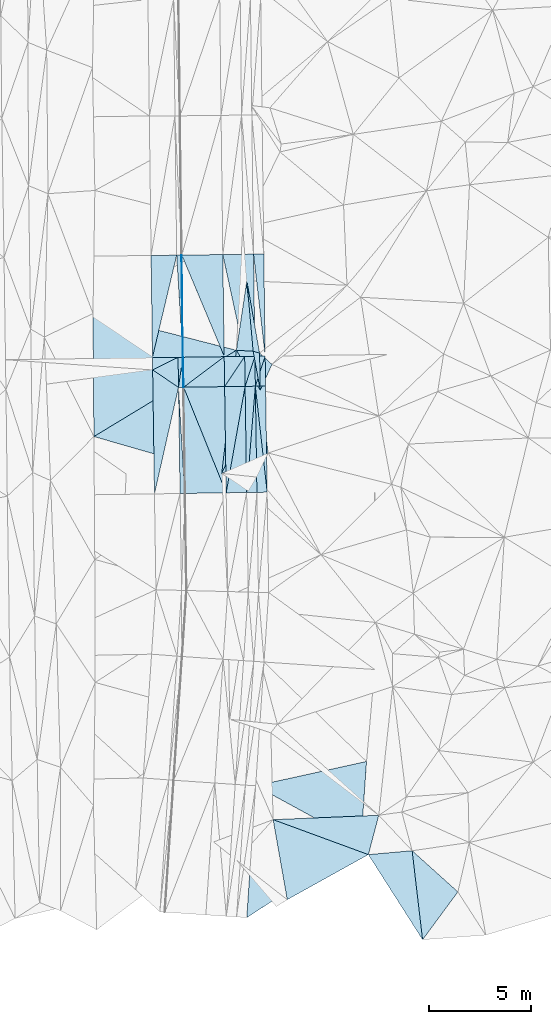
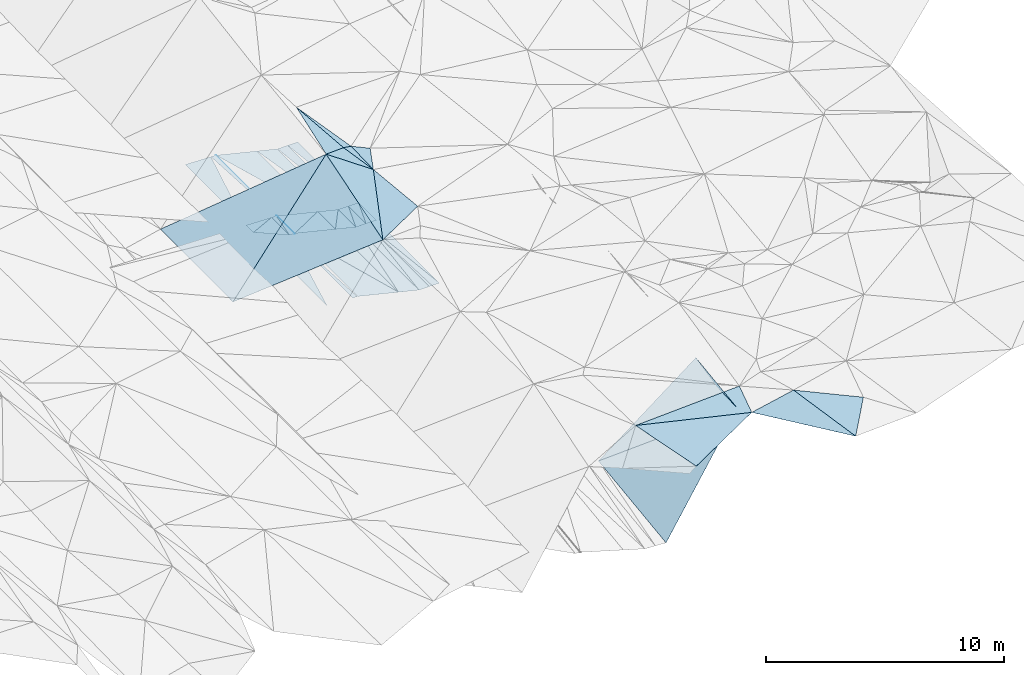
# One storey, part 28 of 275: 46 plates.
"""IFC2X3 building model written with IfcOpenShell, lengths in millimetres."""

import ifcopenshell
import ifcopenshell.guid

model = None  # the IFC model being written
_history = None  # IfcOwnerHistory: only IFC2X3 demands one
_inside = {}  # id of a spatial element -> (the spatial element, [elements in it])
_under = {}  # id of a project, library or spatial element -> (it, [spatial elements below it])
_declared = {}  # id of a project -> (the project, [libraries it declares])
_typed = {}  # id of a type object -> (the type object, [elements of that type])
_made_of = {}  # id of a material, layer set ... -> (it, [elements and type objects made of it])


def new_model(schema):
    """Start an empty IFC model of exactly this schema.

    Asked for "IFC4X3", IfcOpenShell would pick the latest addendum, in which some entities
    have other attributes; the version numbers below select the first issue.
    IFC2X3 requires an IfcOwnerHistory on every rooted entity: one is made here for all.
    """
    global model, _history
    if schema == "IFC4X3":
        model = ifcopenshell.file(schema_version=(4, 3, 0, 0))
    else:
        model = ifcopenshell.file(schema=schema)
    _inside.clear()
    _under.clear()
    _declared.clear()
    _typed.clear()
    _made_of.clear()
    _history = None
    if model.schema == "IFC2X3":
        org = make("IfcOrganization", Name="unknown")
        user = make(
            "IfcPersonAndOrganization",
            ThePerson=make("IfcPerson", FamilyName="unknown"),
            TheOrganization=org,
        )
        app = make(
            "IfcApplication",
            ApplicationDeveloper=org,
            Version="unknown",
            ApplicationFullName="unknown",
            ApplicationIdentifier="unknown",
        )
        _history = make(
            "IfcOwnerHistory",
            OwningUser=user,
            OwningApplication=app,
            ChangeAction="ADDED",
            CreationDate=0,
        )
    return model


def make(cls, **values):
    """One entity of the class cls with the attributes given. An attribute that is None is left unset."""
    return model.create_entity(
        cls, **{name: value for name, value in values.items() if value is not None}
    )


def rooted(cls, **values):
    """An entity with a GlobalId (a new one), such as an element, a storey or a relation."""
    return make(cls, GlobalId=ifcopenshell.guid.new(), OwnerHistory=_history, **values)


def si_unit(unit_type, name, prefix=None):
    """IfcSIUnit, for example si_unit("LENGTHUNIT", "METRE", prefix="MILLI")."""
    return make("IfcSIUnit", UnitType=unit_type, Prefix=prefix, Name=name)


def assignment(units):
    """IfcUnitAssignment: the units of a project."""
    return None if units is None else make("IfcUnitAssignment", Units=units)


def point(xyz):
    """IfcCartesianPoint."""
    return None if xyz is None else make("IfcCartesianPoint", Coordinates=xyz)


def direction(xyz):
    """IfcDirection."""
    return None if xyz is None else make("IfcDirection", DirectionRatios=xyz)


def frame(location, z_axis=None, x_axis=None):
    """IfcAxis2Placement3D, a coordinate frame: its origin and axes. An axis left out is left unset."""
    return make(
        "IfcAxis2Placement3D",
        Location=point(location),
        Axis=direction(z_axis),
        RefDirection=direction(x_axis),
    )


def origin_with_axes():
    """The frame at (0, 0, 0) with the z axis (0, 0, 1) and the x axis (1, 0, 0) written out."""
    return frame((0.0, 0.0, 0.0), z_axis=(0.0, 0.0, 1.0), x_axis=(1.0, 0.0, 0.0))


def place(relative_to, where):
    """IfcLocalPlacement: puts the frame where relative to a parent placement (None: the world)."""
    return make(
        "IfcLocalPlacement", PlacementRelTo=relative_to, RelativePlacement=where
    )


def context(
    kind, dimensions, precision=None, world=None, true_north=None, identifier=None
):
    """IfcGeometricRepresentationContext, for example the 3D "Model" context."""
    return make(
        "IfcGeometricRepresentationContext",
        ContextIdentifier=identifier,
        ContextType=kind,
        CoordinateSpaceDimension=dimensions,
        Precision=precision,
        WorldCoordinateSystem=world,
        TrueNorth=true_north,
    )


def subcontext(parent, identifier, kind, view, scale=None):
    """IfcGeometricRepresentationSubContext, for example "Body" below "Model"."""
    return make(
        "IfcGeometricRepresentationSubContext",
        ContextIdentifier=identifier,
        ContextType=kind,
        ParentContext=parent,
        TargetScale=scale,
        TargetView=view,
    )


def project(units=None, contexts=None):
    """IfcProject with its units and contexts."""
    return rooted(
        "IfcProject",
        Name="project",
        RepresentationContexts=contexts,
        UnitsInContext=assignment(units),
    )


def spatial(cls, under=None, at=None, **own):
    """A site, building, storey or space (cls), placed at a placement, below another one or the project."""
    s = rooted(cls, ObjectPlacement=at, **own)
    if under is not None:
        _under.setdefault(under.id(), (under, []))[1].append(s)
    return s


def polyline(points):
    """IfcPolyline through the points."""
    return make("IfcPolyline", Points=[point(p) for p in points])


def outline(outer, holes=None, kind="AREA"):
    """IfcArbitraryClosedProfileDef: a profile drawn as a closed curve; with holes, ...WithVoids."""
    if holes is None:
        return make("IfcArbitraryClosedProfileDef", ProfileType=kind, OuterCurve=outer)
    return make(
        "IfcArbitraryProfileDefWithVoids",
        ProfileType=kind,
        OuterCurve=outer,
        InnerCurves=holes,
    )


def extrude(swept, where, along, depth):
    """IfcExtrudedAreaSolid: the profile swept, set in the frame where, extruded along a direction by depth."""
    return make(
        "IfcExtrudedAreaSolid",
        SweptArea=swept,
        Position=where,
        ExtrudedDirection=direction(along),
        Depth=depth,
    )


def shape(context_of_items, identifier, shape_type, items):
    """IfcShapeRepresentation: the items that make up one representation, for example the "Body"."""
    return make(
        "IfcShapeRepresentation",
        ContextOfItems=context_of_items,
        RepresentationIdentifier=identifier,
        RepresentationType=shape_type,
        Items=items,
    )


def material(Name=None, Category=None):
    """IfcMaterial."""
    return make("IfcMaterial", Name=Name, Category=Category)


def made_of(thing, what):
    """Note that an element or type object is made of a material, layer set ...; save() writes the relation."""
    if what is not None:
        _made_of.setdefault(what.id(), (what, []))[1].append(thing)
    return thing


def type_object(cls, material=None, **own):
    """A type object (cls), such as IfcWallType, which elements share."""
    return made_of(rooted(cls, **own), material)


def element(
    cls,
    number,
    at=None,
    inside=None,
    cuts=None,
    type_object=None,
    material=None,
    context=None,
    identifier="Body",
    shape_type=None,
    held_by="IfcProductDefinitionShape",
    body=None,
    shapes=None,
    **own,
):
    """One element of the class cls, such as IfcWall. Its Tag is "e" and its number.

    at: its placement. inside: the storey or other place that contains it. cuts: it is an
    opening in that element (IfcRelVoidsElement). A single representation is given by context,
    identifier, shape_type and body (its items); several are given by shapes. held_by: the class
    of the entity that holds the representations. save() writes the other relations.
    """
    e = rooted(cls, Tag="e%d" % number, ObjectPlacement=at, **own)
    if body is not None:
        shapes = [shape(context, identifier, shape_type, body)]
    if shapes is not None:
        e.Representation = make(held_by, Representations=shapes)
    if inside is not None:
        _inside.setdefault(inside.id(), (inside, []))[1].append(e)
    if cuts is not None:
        rooted(
            "IfcRelVoidsElement", RelatingBuildingElement=cuts, RelatedOpeningElement=e
        )
    if type_object is not None:
        _typed.setdefault(type_object.id(), (type_object, []))[1].append(e)
    return made_of(e, material)


def aggregate(whole, parts):
    """IfcRelAggregates: a whole, such as a stair, and the parts it consists of."""
    return rooted("IfcRelAggregates", RelatingObject=whole, RelatedObjects=parts)


def save(model, path):
    """Write the relations noted so far, then the file.

    IfcRelAggregates (storeys below a building ...), IfcRelContainedInSpatialStructure (elements
    in a storey), IfcRelDefinesByType, IfcRelAssociatesMaterial and IfcRelDeclares: one each for
    every whole, place, type object, material and project.
    """
    for whole, parts in _under.values():
        aggregate(whole, parts)
    for where, things in _inside.values():
        rooted(
            "IfcRelContainedInSpatialStructure",
            RelatedElements=things,
            RelatingStructure=where,
        )
    for kind, things in _typed.values():
        rooted("IfcRelDefinesByType", RelatedObjects=things, RelatingType=kind)
    for what, things in _made_of.values():
        rooted("IfcRelAssociatesMaterial", RelatedObjects=things, RelatingMaterial=what)
    for by, libraries in _declared.values():
        rooted("IfcRelDeclares", RelatingContext=by, RelatedDefinitions=libraries)
    model.write(path)


model = new_model("IFC2X3")

# Units and contexts
model_context = context("Model", 3, precision=1e-05, world=origin_with_axes())
body_context = subcontext(model_context, "Body", "Model", "MODEL_VIEW")
ifc_project = project(units=[si_unit("LENGTHUNIT", "METRE", prefix="MILLI"), si_unit("AREAUNIT", "SQUARE_METRE"), si_unit("VOLUMEUNIT", "CUBIC_METRE"), si_unit("MASSUNIT", "GRAM", prefix="KILO"), si_unit("TIMEUNIT", "SECOND"), si_unit("PLANEANGLEUNIT", "RADIAN"), si_unit("SOLIDANGLEUNIT", "STERADIAN"), si_unit("THERMODYNAMICTEMPERATUREUNIT", "DEGREE_CELSIUS"), si_unit("LUMINOUSINTENSITYUNIT", "LUMEN")], contexts=[model_context])

# Site, building, storey
site_placement = place(None, origin_with_axes())
site = spatial("IfcSite", under=ifc_project, at=site_placement, CompositionType="ELEMENT")
building_placement = place(site_placement, origin_with_axes())
building = spatial("IfcBuilding", under=site, at=building_placement, Name="Undefined", CompositionType="ELEMENT")
storey_placement = place(building_placement, origin_with_axes())
storey = spatial("IfcBuildingStorey", under=building, at=storey_placement, Name="Undefined", CompositionType="ELEMENT", Elevation=0.0)

# Plates
ifc_material = material()
plate_type_1 = type_object("IfcPlateType", PredefinedType="NOTDEFINED")
plate_1_placement = place(storey_placement, frame((-56941.8178044151, -6357.65182748982, 40803.0364137105), z_axis=(-0.0353297863927327, 0.0204032928486913, -0.999167409313562), x_axis=(-0.0145680960377885, 0.999674825691065, 0.0209287710430521)))
element("IfcPlate", 1, at=plate_1_placement, inside=storey, type_object=plate_type_1, material=ifc_material, Name="00_PR", context=body_context, shape_type="SweptSolid", body=[
    extrude(outline(polyline([(0.0, 0.0), (6049.75830078125, -2.35013430938125e-09), (5183.77392578125, 1250.3623046875), (0.0, 0.0)])), frame((-8.85201319254618e-08, 2.18876761149539e-07, -0.5000001331573), z_axis=(0.0, 0.0, 1.0), x_axis=(1.0, 0.0, 0.0)), (0.0, 0.0, 1.0), 1.0),
])
plate_type_2 = type_object("IfcPlateType", PredefinedType="NOTDEFINED")
plate_2_placement = place(storey_placement, frame((-55558.864264753, 333.224894072824, 40889.1297464698), z_axis=(-0.050207080738683, 0.021132013568532, -0.998515241268875), x_axis=(-0.0135497510538627, 0.999669703891426, 0.0218377509832748)))
element("IfcPlate", 2, at=plate_2_placement, inside=storey, type_object=plate_type_2, material=ifc_material, Name="00_PR", context=body_context, shape_type="SweptSolid", body=[
    extrude(outline(polyline([(0.0, 0.0), (4962.09521484375, 3.05590219795704e-10), (4962.06494140625, 20.0251941680908), (0.0, 0.0)])), frame((-8.85201319254618e-08, 2.18876761149539e-07, -0.5000001331573), z_axis=(0.0, 0.0, 1.0), x_axis=(1.0, 0.0, 0.0)), (0.0, 0.0, 1.0), 1.0),
])
plate_3_placement = place(storey_placement, frame((-55517.9188380509, -1152.88416207165, 40855.2377295211), z_axis=(-0.0496313828432934, 0.0213955677100842, -0.998538409636518), x_axis=(-0.0277638170463829, 0.999354615861594, 0.0227930300561567)))
element("IfcPlate", 3, at=plate_3_placement, inside=storey, type_object=plate_type_2, material=ifc_material, Name="00_PR", context=body_context, shape_type="SweptSolid", body=[
    extrude(outline(polyline([(0.0, 0.0), (1462.376953125, 1.30967237055302e-10), (1462.0791015625, 20.0225772857666), (0.0, 0.0)])), frame((-8.85201319254618e-08, 2.18876761149539e-07, -0.5000001331573), z_axis=(0.0, 0.0, 1.0), x_axis=(1.0, 0.0, 0.0)), (0.0, 0.0, 1.0), 1.0),
])
plate_4_placement = place(storey_placement, frame((-55517.9191398334, -1152.88417101758, 40855.2377443623), z_axis=(-0.0502343597940609, 0.0213781283682467, -0.99850863026994), x_axis=(-0.998651445147197, -0.0141938470544001, 0.0499382199443619)))
element("IfcPlate", 4, at=plate_4_placement, inside=storey, type_object=plate_type_2, material=ifc_material, Name="00_PR", context=body_context, shape_type="SweptSolid", body=[
    extrude(outline(polyline([(0.0, 0.0), (20.0247211456299, -8.70841176947579e-11), (21.4675941467285, 1462.21936035156), (0.0, 0.0)])), frame((-8.85201319254618e-08, 2.18876761149539e-07, -0.5000001331573), z_axis=(0.0, 0.0, 1.0), x_axis=(1.0, 0.0, 0.0)), (0.0, 0.0, 1.0), 1.0),
])
plate_type_3 = type_object("IfcPlateType", PredefinedType="NOTDEFINED")
plate_5_placement = place(storey_placement, frame((-51606.4208821664, 5346.49573586657, 40246.4901238692), z_axis=(-0.000287064842259564, 0.0218505512888936, -0.999761206990023), x_axis=(0.0135494950592206, -0.999669386481595, -0.0218524349936422)))
element("IfcPlate", 5, at=plate_5_placement, inside=storey, type_object=plate_type_3, material=ifc_material, Name="00_PR", context=body_context, shape_type="SweptSolid", body=[
    extrude(outline(polyline([(0.0, 0.0), (4958.7607421875, -1.94268068298697e-09), (-0.208078876137733, 500.0), (0.0, 0.0)])), frame((-8.85201319254618e-08, 2.18876761149539e-07, -0.5000001331573), z_axis=(0.0, 0.0, 1.0), x_axis=(1.0, 0.0, 0.0)), (0.0, 0.0, 1.0), 1.0),
])
plate_6_placement = place(storey_placement, frame((-52106.3777888769, 5339.92747869403, 40246.490123646), z_axis=(-0.000287081021315416, 0.0218487238851854, -0.999761246923022), x_axis=(0.0135496300479079, -0.999669424588275, -0.021850607975812)))
element("IfcPlate", 6, at=plate_6_placement, inside=storey, type_object=plate_type_3, material=ifc_material, Name="00_PR", context=body_context, shape_type="SweptSolid", body=[
    extrude(outline(polyline([(0.0, 0.0), (4959.17578125, 1.5788828022778e-09), (-0.207226857542992, 499.999603271484), (0.0, 0.0)])), frame((-8.85201319254618e-08, 2.18876761149539e-07, -0.5000001331573), z_axis=(0.0, 0.0, 1.0), x_axis=(1.0, 0.0, 0.0)), (0.0, 0.0, 1.0), 1.0),
])
plate_7_placement = place(storey_placement, frame((-51538.8784994366, 364.063115143073, 40137.5531222983), z_axis=(-0.000314517182269425, 0.0221231376374528, -0.999755203967459), x_axis=(0.0140906790476609, -0.999655901113563, -0.0221253730546399)))
element("IfcPlate", 7, at=plate_7_placement, inside=storey, type_object=plate_type_3, material=ifc_material, Name="00_PR", context=body_context, shape_type="SweptSolid", body=[
    extrude(outline(polyline([(0.0, 0.0), (1460.58557128906, -3.63797880709171e-11), (1460.64611816406, 500.000762939453), (0.0, 0.0)])), frame((-8.85201319254618e-08, 2.18876761149539e-07, -0.5000001331573), z_axis=(0.0, 0.0, 1.0), x_axis=(1.0, 0.0, 0.0)), (0.0, 0.0, 1.0), 1.0),
])
plate_8_placement = place(storey_placement, frame((-51518.2978468996, -1096.02060175882, 40105.237106606), z_axis=(-0.000293615235016061, 0.0206529359838606, -0.999786662256174), x_axis=(0.0146461580413869, -0.999679378681155, -0.0206550210430108)))
element("IfcPlate", 8, at=plate_8_placement, inside=storey, type_object=plate_type_3, material=ifc_material, Name="00_PR", context=body_context, shape_type="SweptSolid", body=[
    extrude(outline(polyline([(0.0, 0.0), (5180.33837890625, 2.69210431724787e-10), (-0.217007249593735, 500.000732421875), (0.0, 0.0)])), frame((-8.85201319254618e-08, 2.18876761149539e-07, -0.5000001331573), z_axis=(0.0, 0.0, 1.0), x_axis=(1.0, 0.0, 0.0)), (0.0, 0.0, 1.0), 1.0),
])
plate_9_placement = place(storey_placement, frame((-52038.830471524, 357.164657838352, 40137.5551221029), z_axis=(-0.000314515267574764, 0.0221213384723832, -0.999755243779365), x_axis=(0.0140898400447904, -0.999655952755373, -0.0221235740390148)))
element("IfcPlate", 9, at=plate_9_placement, inside=storey, type_object=plate_type_3, material=ifc_material, Name="00_PR", context=body_context, shape_type="SweptSolid", body=[
    extrude(outline(polyline([(0.0, 0.0), (1460.79467773438, 1.45519152283669e-11), (1460.85620117188, 499.999450683594), (0.0, 0.0)])), frame((-8.85201319254618e-08, 2.18876761149539e-07, -0.5000001331573), z_axis=(0.0, 0.0, 1.0), x_axis=(1.0, 0.0, 0.0)), (0.0, 0.0, 1.0), 1.0),
])
plate_10_placement = place(storey_placement, frame((-52018.2481057998, -1103.1282245535, 40105.2371062211), z_axis=(-0.000311525496391537, 0.0206509464012298, -0.999786697933414), x_axis=(0.0146462390507561, -0.99967941317538, -0.0206532940470902)))
element("IfcPlate", 10, at=plate_10_placement, inside=storey, type_object=plate_type_3, material=ifc_material, Name="00_PR", context=body_context, shape_type="SweptSolid", body=[
    extrude(outline(polyline([(0.0, 0.0), (5180.77197265625, 4.07453626394272e-10), (5180.98876953125, 499.999908447266), (0.0, 0.0)])), frame((-8.85201319254618e-08, 2.18876761149539e-07, -0.5000001331573), z_axis=(0.0, 0.0, 1.0), x_axis=(1.0, 0.0, 0.0)), (0.0, 0.0, 1.0), 1.0),
])
plate_11_placement = place(storey_placement, frame((-52018.2481044546, -1103.12748920171, 40105.2371218576), z_axis=(-0.000309235493463831, 0.0221214128853827, -0.999755243779878), x_axis=(-0.0140898400448231, 0.999655952755456, 0.0221235740352296)))
element("IfcPlate", 11, at=plate_11_placement, inside=storey, type_object=plate_type_3, material=ifc_material, Name="00_PR", context=body_context, shape_type="SweptSolid", body=[
    extrude(outline(polyline([(0.0, 0.0), (1460.79467773438, 1.45519152283669e-11), (1460.646484375, 499.999542236328), (0.0, 0.0)])), frame((-8.85201319254618e-08, 2.18876761149539e-07, -0.5000001331573), z_axis=(0.0, 0.0, 1.0), x_axis=(1.0, 0.0, 0.0)), (0.0, 0.0, 1.0), 1.0),
])
plate_12_placement = place(storey_placement, frame((-51942.3692855471, -6282.23909670942, 39998.2371056729), z_axis=(-0.000311525496391537, 0.0206509464012298, -0.999786697933414), x_axis=(-0.0146462390505551, 0.999679413175508, 0.0206532940410656)))
element("IfcPlate", 12, at=plate_12_placement, inside=storey, type_object=plate_type_3, material=ifc_material, Name="00_PR", context=body_context, shape_type="SweptSolid", body=[
    extrude(outline(polyline([(0.0, 0.0), (5180.77197265625, 4.07453626394272e-10), (0.216174393892288, 500.000305175781), (0.0, 0.0)])), frame((-8.85201319254618e-08, 2.18876761149539e-07, -0.5000001331573), z_axis=(0.0, 0.0, 1.0), x_axis=(1.0, 0.0, 0.0)), (0.0, 0.0, 1.0), 1.0),
])
plate_13_placement = place(storey_placement, frame((-52518.1970335013, -1110.2356233127, 40105.237121261), z_axis=(-0.00030536461958494, 0.0221183511351763, -0.999755312711821), x_axis=(-0.014090546045561, 0.99965601176035, 0.0221204580316273)))
element("IfcPlate", 13, at=plate_13_placement, inside=storey, type_object=plate_type_3, material=ifc_material, Name="00_PR", context=body_context, shape_type="SweptSolid", body=[
    extrude(outline(polyline([(0.0, 0.0), (1461.09094238281, 3.63797880709171e-11), (1460.85583496094, 500.00048828125), (0.0, 0.0)])), frame((-8.85201319254618e-08, 2.18876761149539e-07, -0.5000001331573), z_axis=(0.0, 0.0, 1.0), x_axis=(1.0, 0.0, 0.0)), (0.0, 0.0, 1.0), 1.0),
])
plate_14_placement = place(storey_placement, frame((-52442.3123578305, -6289.78089681646, 39998.2371054212), z_axis=(-0.000293588266677345, 0.0206494800090892, -0.999786733649374), x_axis=(-0.0146461420537325, 0.999679450316034, 0.020651565044169)))
element("IfcPlate", 14, at=plate_14_placement, inside=storey, type_object=plate_type_3, material=ifc_material, Name="00_PR", context=body_context, shape_type="SweptSolid", body=[
    extrude(outline(polyline([(0.0, 0.0), (5181.20556640625, 2.40106601268053e-10), (5180.98876953125, 499.999420166016), (0.0, 0.0)])), frame((-8.85201319254618e-08, 2.18876761149539e-07, -0.5000001331573), z_axis=(0.0, 0.0, 1.0), x_axis=(1.0, 0.0, 0.0)), (0.0, 0.0, 1.0), 1.0),
])
plate_type_4 = type_object("IfcPlateType", PredefinedType="NOTDEFINED")
plate_15_placement = place(storey_placement, frame((-52606.4555192209, 5333.35633804358, 40246.5050406188), z_axis=(-0.242737735417362, 0.0179086597421493, -0.969926632127756), x_axis=(0.0135495010582724, -0.999669466247102, -0.0218487819868052)))
element("IfcPlate", 15, at=plate_15_placement, inside=storey, type_object=plate_type_4, material=ifc_material, Name="00_PR", context=body_context, shape_type="SweptSolid", body=[
    extrude(outline(polyline([(0.0, 0.0), (4959.58984375, 1.04773789644241e-09), (-5.8770489692688, 1030.76025390625), (0.0, 0.0)])), frame((-8.85201319254618e-08, 2.18876761149539e-07, -0.5000001331573), z_axis=(0.0, 0.0, 1.0), x_axis=(1.0, 0.0, 0.0)), (0.0, 0.0, 1.0), 1.0),
])
plate_type_5 = type_object("IfcPlateType", PredefinedType="NOTDEFINED")
plate_16_placement = place(storey_placement, frame((-55606.1971806718, 5293.94233465812, 40996.5050405204), z_axis=(-0.242737861908812, 0.0179050894554546, -0.969926666386449), x_axis=(0.970058767212209, 0.01274581605249, -0.242535631048069)))
element("IfcPlate", 16, at=plate_16_placement, inside=storey, type_object=plate_type_5, material=ifc_material, Name="00_PR", context=body_context, shape_type="SweptSolid", body=[
    extrude(outline(polyline([(0.0, 0.0), (2061.552734375, -7.5924617704004e-09), (2089.82958984375, 4960.33935546875), (0.0, 0.0)])), frame((-8.85201319254618e-08, 2.18876761149539e-07, -0.5000001331573), z_axis=(0.0, 0.0, 1.0), x_axis=(1.0, 0.0, 0.0)), (0.0, 0.0, 1.0), 1.0),
])
plate_type_6 = type_object("IfcPlateType", PredefinedType="NOTDEFINED")
plate_17_placement = place(storey_placement, frame((-55626.0994221338, 5293.68124695893, 40997.4907460091), z_axis=(-0.050207080738683, 0.021132013568532, -0.998515241268875), x_axis=(0.0135497510559135, -0.999669703891641, -0.0218377509721336)))
element("IfcPlate", 17, at=plate_17_placement, inside=storey, type_object=plate_type_6, material=ifc_material, Name="00_PR", context=body_context, shape_type="SweptSolid", body=[
    extrude(outline(polyline([(0.0, 0.0), (4962.09521484375, 3.05590219795704e-10), (-0.346415966749191, 230.286651611328), (0.0, 0.0)])), frame((-8.85201319254618e-08, 2.18876761149539e-07, -0.5000001331573), z_axis=(0.0, 0.0, 1.0), x_axis=(1.0, 0.0, 0.0)), (0.0, 0.0, 1.0), 1.0),
])
plate_18_placement = place(storey_placement, frame((-55558.5203039692, 308.548932031358, 40888.5697445091), z_axis=(-0.0502343597940609, 0.0213781283682467, -0.99850863026994), x_axis=(0.0140905100449485, -0.999656208614616, -0.0221115830488006)))
element("IfcPlate", 18, at=plate_18_placement, inside=storey, type_object=plate_type_6, material=ifc_material, Name="00_PR", context=body_context, shape_type="SweptSolid", body=[
    extrude(outline(polyline([(0.0, 0.0), (1462.21997070313, -8.00355337560177e-11), (1461.994140625, 230.287643432617), (0.0, 0.0)])), frame((-8.85201319254618e-08, 2.18876761149539e-07, -0.5000001331573), z_axis=(0.0, 0.0, 1.0), x_axis=(1.0, 0.0, 0.0)), (0.0, 0.0, 1.0), 1.0),
])
plate_19_placement = place(storey_placement, frame((-55691.9674013513, -6338.7991663607, 40760.7377279265), z_axis=(-0.0502325611855882, 0.0198808556331222, -0.998539654383356), x_axis=(-0.0146461610550057, 0.999679665323876, 0.0206411410608503)))
element("IfcPlate", 19, at=plate_19_placement, inside=storey, type_object=plate_type_6, material=ifc_material, Name="00_PR", context=body_context, shape_type="SweptSolid", body=[
    extrude(outline(polyline([(0.0, 0.0), (5184.0205078125, 4.80213202536106e-10), (-0.138187646865845, 230.287048339844), (0.0, 0.0)])), frame((-8.85201319254618e-08, 2.18876761149539e-07, -0.5000001331573), z_axis=(0.0, 0.0, 1.0), x_axis=(1.0, 0.0, 0.0)), (0.0, 0.0, 1.0), 1.0),
])
plate_type_7 = type_object("IfcPlateType", PredefinedType="NOTDEFINED")
plate_20_placement = place(storey_placement, frame((-57038.7119892179, 312.553596358796, 40943.3394093187), z_axis=(-0.0341671885636603, 0.0212943011414639, -0.999189249323947), x_axis=(-0.0135491480650036, 0.999671235842545, 0.0217678849627542)))
element("IfcPlate", 20, at=plate_20_placement, inside=storey, type_object=plate_type_7, material=ifc_material, Name="00_PR", context=body_context, shape_type="SweptSolid", body=[
    extrude(outline(polyline([(0.0, 0.0), (4968.55810546875, -8.73114913702011e-11), (4961.87451171875, 1250.71508789063), (0.0, 0.0)])), frame((-8.85201319254618e-08, 2.18876761149539e-07, -0.5000001331573), z_axis=(0.0, 0.0, 1.0), x_axis=(1.0, 0.0, 0.0)), (0.0, 0.0, 1.0), 1.0),
])
plate_type_8 = type_object("IfcPlateType", PredefinedType="NOTDEFINED")
plate_21_placement = place(storey_placement, frame((-52518.3182624784, -1110.2384421541, 40105.2520260959), z_axis=(-0.242762746308585, 0.0164806416583718, -0.9699456878894), x_axis=(0.0146461420534593, -0.999679450316063, -0.0206515650429951)))
element("IfcPlate", 21, at=plate_21_placement, inside=storey, type_object=plate_type_8, material=ifc_material, Name="00_PR", context=body_context, shape_type="SweptSolid", body=[
    extrude(outline(polyline([(0.0, 0.0), (5181.20556640625, 2.40106601268053e-10), (5176.4755859375, 1030.76501464844), (0.0, 0.0)])), frame((-8.85201319254618e-08, 2.18876761149539e-07, -0.5000001331573), z_axis=(0.0, 0.0, 1.0), x_axis=(1.0, 0.0, 0.0)), (0.0, 0.0, 1.0), 1.0),
])
plate_22_placement = place(storey_placement, frame((-53442.3192450636, -6304.86526505675, 40248.2520255617), z_axis=(-0.242746185292985, 0.0164776026975475, -0.969949884341993), x_axis=(-0.014646228053211, 0.999679520300063, 0.0206481160508506)))
element("IfcPlate", 22, at=plate_22_placement, inside=storey, type_object=plate_type_8, material=ifc_material, Name="00_PR", context=body_context, shape_type="SweptSolid", body=[
    extrude(outline(polyline([(0.0, 0.0), (5182.07080078125, -2.69210431724787e-10), (5176.47607421875, 1030.76110839844), (0.0, 0.0)])), frame((-8.85201319254618e-08, 2.18876761149539e-07, -0.5000001331573), z_axis=(0.0, 0.0, 1.0), x_axis=(1.0, 0.0, 0.0)), (0.0, 0.0, 1.0), 1.0),
])
plate_type_9 = type_object("IfcPlateType", PredefinedType="NOTDEFINED")
plate_23_placement = place(storey_placement, frame((-55767.8940519455, -1156.43844057982, 40867.7377433844), z_axis=(-0.0502125545366383, 0.0213750292553393, -0.998509793387746), x_axis=(-0.0140900000523677, 0.99965629232914, 0.0221081230610403)))
element("IfcPlate", 23, at=plate_23_placement, inside=storey, type_object=plate_type_9, material=ifc_material, Name="00_PR", context=body_context, shape_type="SweptSolid", body=[
    extrude(outline(polyline([(0.0, 0.0), (1462.494140625, 2.91038304567337e-11), (1461.99438476563, 230.286636352539), (0.0, 0.0)])), frame((-8.85201319254618e-08, 2.18876761149539e-07, -0.5000001331573), z_axis=(0.0, 0.0, 1.0), x_axis=(1.0, 0.0, 0.0)), (0.0, 0.0, 1.0), 1.0),
])
plate_type_10 = type_object("IfcPlateType", PredefinedType="NOTDEFINED")
plate_24_placement = place(storey_placement, frame((-53538.8127869472, 336.726269089667, 40387.576039377), z_axis=(-0.242760500225327, 0.0180346048840314, -0.969918600995478), x_axis=(0.0140904320510461, -0.999656151138897, -0.0221142310465747)))
element("IfcPlate", 24, at=plate_24_placement, inside=storey, type_object=plate_type_10, material=ifc_material, Name="00_PR", context=body_context, shape_type="SweptSolid", body=[
    extrude(outline(polyline([(0.0, 0.0), (1461.68322753906, -7.27595761418343e-11), (1450.86975097656, 2061.52490234375), (0.0, 0.0)])), frame((-8.85201319254618e-08, 2.18876761149539e-07, -0.5000001331573), z_axis=(0.0, 0.0, 1.0), x_axis=(1.0, 0.0, 0.0)), (0.0, 0.0, 1.0), 1.0),
])
plate_type_11 = type_object("IfcPlateType", PredefinedType="NOTDEFINED")
plate_25_placement = place(storey_placement, frame((-46592.4673051098, -19414.0699580774, 42440.9737190631), z_axis=(0.44679726660557, -0.0115737995490838, -0.894560366726466), x_axis=(-0.0696235519876854, -0.997333561490274, -0.0218707140657269)))
element("IfcPlate", 25, at=plate_25_placement, inside=storey, type_object=plate_type_11, material=ifc_material, Name="00_PR", context=body_context, shape_type="SweptSolid", body=[
    extrude(outline(polyline([(0.0, 0.0), (4000.966796875, 6.87941792421043e-09), (1619.91870117188, 5939.57373046875), (0.0, 0.0)])), frame((-8.85201319254618e-08, 2.18876761149539e-07, -0.5000001331573), z_axis=(0.0, 0.0, 1.0), x_axis=(1.0, 0.0, 0.0)), (0.0, 0.0, 1.0), 1.0),
])
plate_type_12 = type_object("IfcPlateType", PredefinedType="NOTDEFINED")
plate_26_placement = place(storey_placement, frame((-52437.5449152699, -27037.5333085249, 39609.4268694112), z_axis=(0.447436526296145, -0.0101232041352685, -0.894258394243004), x_axis=(0.0673666259477489, 0.99747647292743, 0.0224148090482824)))
element("IfcPlate", 26, at=plate_26_placement, inside=storey, type_object=plate_type_12, material=ifc_material, Name="00_PR", context=body_context, shape_type="SweptSolid", body=[
    extrude(outline(polyline([(0.0, 0.0), (6452.1181640625, -1.04555510915816e-08), (4060.50170898438, 5935.326171875), (0.0, 0.0)])), frame((-8.85201319254618e-08, 2.18876761149539e-07, -0.5000001331573), z_axis=(0.0, 0.0, 1.0), x_axis=(1.0, 0.0, 0.0)), (0.0, 0.0, 1.0), 1.0),
])
plate_type_13 = type_object("IfcPlateType", PredefinedType="NOTDEFINED")
plate_27_placement = place(storey_placement, frame((-52538.9058308175, 350.35067244107, 40137.5720397911), z_axis=(-0.242760661852887, 0.0180406158143761, -0.969918448756279), x_axis=(0.014090546045543, -0.999656011760378, -0.0221204580303599)))
element("IfcPlate", 27, at=plate_27_placement, inside=storey, type_object=plate_type_13, material=ifc_material, Name="00_PR", context=body_context, shape_type="SweptSolid", body=[
    extrude(outline(polyline([(0.0, 0.0), (1461.09094238281, 3.63797880709171e-11), (1455.68347167969, 1030.76208496094), (0.0, 0.0)])), frame((-8.85201319254618e-08, 2.18876761149539e-07, -0.5000001331573), z_axis=(0.0, 0.0, 1.0), x_axis=(1.0, 0.0, 0.0)), (0.0, 0.0, 1.0), 1.0),
])
plate_type_14 = type_object("IfcPlateType", PredefinedType="NOTDEFINED")
plate_28_placement = place(storey_placement, frame((-55538.6181291643, 308.827429177637, 40887.5960397212), z_axis=(-0.242764359156254, 0.0180400678709986, -0.969917533543272), x_axis=(0.970045823005158, 0.0135328950537076, -0.242544762923695)))
element("IfcPlate", 28, at=plate_28_placement, inside=storey, type_object=plate_type_14, material=ifc_material, Name="00_PR", context=body_context, shape_type="SweptSolid", body=[
    extrude(outline(polyline([(0.0, 0.0), (2061.5576171875, -6.18456397205591e-10), (8.049241065979, 1462.19409179688), (0.0, 0.0)])), frame((-8.85201319254618e-08, 2.18876761149539e-07, -0.5000001331573), z_axis=(0.0, 0.0, 1.0), x_axis=(1.0, 0.0, 0.0)), (0.0, 0.0, 1.0), 1.0),
])
plate_type_15 = type_object("IfcPlateType", PredefinedType="NOTDEFINED")
plate_29_placement = place(storey_placement, frame((-55518.0153960463, -1152.88662022841, 40855.2520233953), z_axis=(-0.242746185292985, 0.0164776026975475, -0.969949884341993), x_axis=(0.970044481623155, 0.0137913040481929, -0.242535571834554)))
element("IfcPlate", 29, at=plate_29_placement, inside=storey, type_object=plate_type_15, material=ifc_material, Name="00_PR", context=body_context, shape_type="SweptSolid", body=[
    extrude(outline(polyline([(0.0, 0.0), (2061.55322265625, 1.61162461154163e-09), (2089.68408203125, 5181.99462890625), (0.0, 0.0)])), frame((-8.85201319254618e-08, 2.18876761149539e-07, -0.5000001331573), z_axis=(0.0, 0.0, 1.0), x_axis=(1.0, 0.0, 0.0)), (0.0, 0.0, 1.0), 1.0),
])
plate_type_16 = type_object("IfcPlateType", PredefinedType="NOTDEFINED")
plate_30_placement = place(storey_placement, frame((-53442.3192450636, -6304.86526505675, 40248.2520255617), z_axis=(-0.242762442029136, 0.016470587454615, -0.969945934827787), x_axis=(-0.970032164370089, -0.0146323480620336, 0.242535553017846)))
element("IfcPlate", 30, at=plate_30_placement, inside=storey, type_object=plate_type_16, material=ifc_material, Name="00_PR", context=body_context, shape_type="SweptSolid", body=[
    extrude(outline(polyline([(0.0, 0.0), (2061.55346679688, 3.43152350978926e-09), (2085.32568359375, 5183.75), (0.0, 0.0)])), frame((-8.85201319254618e-08, 2.18876761149539e-07, -0.5000001331573), z_axis=(0.0, 0.0, 1.0), x_axis=(1.0, 0.0, 0.0)), (0.0, 0.0, 1.0), 1.0),
])
plate_type_17 = type_object("IfcPlateType", PredefinedType="NOTDEFINED")
plate_31_placement = place(storey_placement, frame((-53518.2170344438, -1124.45433388774, 40355.2520384637), z_axis=(-0.242752338591244, 0.018034765048291, -0.969920640752703), x_axis=(-0.0140904320506905, 0.999656151138891, 0.0221142310470777)))
element("IfcPlate", 31, at=plate_31_placement, inside=storey, type_object=plate_type_17, material=ifc_material, Name="00_PR", context=body_context, shape_type="SweptSolid", body=[
    extrude(outline(polyline([(0.0, 0.0), (1461.68322753906, -7.27595761418343e-11), (1455.68518066406, 1030.759765625), (0.0, 0.0)])), frame((-8.85201319254618e-08, 2.18876761149539e-07, -0.5000001331573), z_axis=(0.0, 0.0, 1.0), x_axis=(1.0, 0.0, 0.0)), (0.0, 0.0, 1.0), 1.0),
])
plate_type_18 = type_object("IfcPlateType", PredefinedType="NOTDEFINED")
plate_32_placement = place(storey_placement, frame((-55788.4927483461, 305.553158077123, 40900.0704131756), z_axis=(-0.0345199332085317, 0.0216108225392512, -0.999170329103329), x_axis=(0.0140900000523356, -0.999656292329146, -0.0221081230607694)))
element("IfcPlate", 32, at=plate_32_placement, inside=storey, type_object=plate_type_18, material=ifc_material, Name="00_PR", context=body_context, shape_type="SweptSolid", body=[
    extrude(outline(polyline([(0.0, 0.0), (1462.494140625, 2.91038304567337e-11), (597.055908203125, 1250.740234375), (0.0, 0.0)])), frame((-8.85201319254618e-08, 2.18876761149539e-07, -0.5000001331573), z_axis=(0.0, 0.0, 1.0), x_axis=(1.0, 0.0, 0.0)), (0.0, 0.0, 1.0), 1.0),
])
plate_type_19 = type_object("IfcPlateType", PredefinedType="NOTDEFINED")
plate_33_placement = place(storey_placement, frame((-57029.950808672, -309.860486118437, 40929.6504087466), z_axis=(-0.0344219460411883, 0.021412788927271, -0.999177973186506), x_axis=(-0.0140760000436119, 0.999660894067386, 0.0219080600502819)))
element("IfcPlate", 33, at=plate_33_placement, inside=storey, type_object=plate_type_19, material=ifc_material, Name="00_PR", context=body_context, shape_type="SweptSolid", body=[
    extrude(outline(polyline([(0.0, 0.0), (600.144409179688, -2.18278728425503e-11), (597.08203125, 1250.72778320313), (0.0, 0.0)])), frame((-8.85201319254618e-08, 2.18876761149539e-07, -0.5000001331573), z_axis=(0.0, 0.0, 1.0), x_axis=(1.0, 0.0, 0.0)), (0.0, 0.0, 1.0), 1.0),
])
plate_type_20 = type_object("IfcPlateType", PredefinedType="NOTDEFINED")
plate_34_placement = place(storey_placement, frame((-52125.7241812597, 604.954690067491, 43009.5024003505), z_axis=(0.0908468171627416, 0.0370412529467842, -0.99517576406961), x_axis=(-0.994601192828224, 0.0537011623476258, -0.0887955651324269)))
element("IfcPlate", 34, at=plate_34_placement, inside=storey, type_object=plate_type_20, material=ifc_material, Name="00", context=body_context, shape_type="SweptSolid", body=[
    extrude(outline(polyline([(0.0, 0.0), (822.113159179688, -1.38675204652827e-09), (481.162475585938, 3421.03540039063), (0.0, 0.0)])), frame((-8.85201319254618e-08, 2.18876761149539e-07, -0.5000001331573), z_axis=(0.0, 0.0, 1.0), x_axis=(1.0, 0.0, 0.0)), (0.0, 0.0, 1.0), 1.0),
])
plate_type_21 = type_object("IfcPlateType", PredefinedType="NOTDEFINED")
plate_35_placement = place(storey_placement, frame((-51777.130784554, -1296.44794294412, 42919.5031434416), z_axis=(0.0921659754590658, 0.0639315182807036, -0.993689183768246), x_axis=(-0.514134019473626, 0.857677122527801, 0.00749423193690223)))
element("IfcPlate", 35, at=plate_35_placement, inside=storey, type_object=plate_type_21, material=ifc_material, Name="00", context=body_context, shape_type="SweptSolid", body=[
    extrude(outline(polyline([(0.0, 0.0), (2268.41137695313, 3.31783667206764e-09), (1810.69897460938, 682.912414550781), (0.0, 0.0)])), frame((-8.85201319254618e-08, 2.18876761149539e-07, -0.5000001331573), z_axis=(0.0, 0.0, 1.0), x_axis=(1.0, 0.0, 0.0)), (0.0, 0.0, 1.0), 1.0),
])
plate_type_22 = type_object("IfcPlateType", PredefinedType="NOTDEFINED")
plate_36_placement = place(storey_placement, frame((-51812.1687165753, 513.97235012849, 43029.5016718279), z_axis=(0.0738887860008739, 0.0355700527211805, -0.996631937403538), x_axis=(-0.958592950891549, 0.278138880299698, -0.0611417841305125)))
element("IfcPlate", 36, at=plate_36_placement, inside=storey, type_object=plate_type_22, material=ifc_material, Name="00", context=body_context, shape_type="SweptSolid", body=[
    extrude(outline(polyline([(0.0, 0.0), (327.108551025391, 7.3305272962898e-10), (1571.95532226563, 3222.6318359375), (0.0, 0.0)])), frame((-8.85201319254618e-08, 2.18876761149539e-07, -0.5000001331573), z_axis=(0.0, 0.0, 1.0), x_axis=(1.0, 0.0, 0.0)), (0.0, 0.0, 1.0), 1.0),
])
plate_type_23 = type_object("IfcPlateType", PredefinedType="NOTDEFINED")
plate_37_placement = place(storey_placement, frame((-51812.1608658414, 513.985630158712, 43029.5029682405), z_axis=(0.08959015828355, 0.0621301254106711, -0.994038958519827), x_axis=(0.738229517210812, -0.674108125319889, 0.0244011330965801)))
element("IfcPlate", 37, at=plate_37_placement, inside=storey, type_object=plate_type_23, material=ifc_material, Name="00", context=body_context, shape_type="SweptSolid", body=[
    extrude(outline(polyline([(0.0, 0.0), (819.634094238281, -3.05590219795704e-10), (1243.60375976563, 1320.77612304688), (0.0, 0.0)])), frame((-8.85201319254618e-08, 2.18876761149539e-07, -0.5000001331573), z_axis=(0.0, 0.0, 1.0), x_axis=(1.0, 0.0, 0.0)), (0.0, 0.0, 1.0), 1.0),
])
plate_type_24 = type_object("IfcPlateType", PredefinedType="NOTDEFINED")
plate_38_placement = place(storey_placement, frame((-43857.2495226005, -28114.1759946594, 42729.5042709535), z_axis=(0.130448910529334, -0.00521558404298421, -0.991441314160753), x_axis=(-0.535644106698466, 0.84111536490066, -0.0749021620998507)))
element("IfcPlate", 38, at=plate_38_placement, inside=storey, type_object=plate_type_24, material=ifc_material, Name="00", context=body_context, shape_type="SweptSolid", body=[
    extrude(outline(polyline([(0.0, 0.0), (4939.77734375, -6.75208866596222e-09), (3934.44848632813, 1914.34436035156), (0.0, 0.0)])), frame((-8.85201319254618e-08, 2.18876761149539e-07, -0.5000001331573), z_axis=(0.0, 0.0, 1.0), x_axis=(1.0, 0.0, 0.0)), (0.0, 0.0, 1.0), 1.0),
])
plate_type_25 = type_object("IfcPlateType", PredefinedType="NOTDEFINED")
plate_39_placement = place(storey_placement, frame((-53659.837173403, -5357.49147762687, 42435.5039005815), z_axis=(0.103079605787016, 0.0704604503351083, -0.99217433942295), x_axis=(0.118032345322709, 0.9895735298843, 0.0825384420130852)))
element("IfcPlate", 39, at=plate_39_placement, inside=storey, type_object=plate_type_25, material=ifc_material, Name="00", context=body_context, shape_type="SweptSolid", body=[
    extrude(outline(polyline([(0.0, 0.0), (6069.89892578125, -4.99130692332983e-09), (4280.8740234375, 1394.6611328125), (0.0, 0.0)])), frame((-8.85201319254618e-08, 2.18876761149539e-07, -0.5000001331573), z_axis=(0.0, 0.0, 1.0), x_axis=(1.0, 0.0, 0.0)), (0.0, 0.0, 1.0), 1.0),
])
plate_type_26 = type_object("IfcPlateType", PredefinedType="NOTDEFINED")
plate_40_placement = place(storey_placement, frame((-52125.7288850213, 604.967177389313, 43009.5026142957), z_axis=(0.08144177746967, 0.0620154792433561, -0.994746860873055), x_axis=(0.958592950891531, -0.278138880299648, 0.0611417841310192)))
element("IfcPlate", 40, at=plate_40_placement, inside=storey, type_object=plate_type_26, material=ifc_material, Name="00", context=body_context, shape_type="SweptSolid", body=[
    extrude(outline(polyline([(0.0, 0.0), (327.108551025391, 7.3305272962898e-10), (857.513549804688, 1734.84020996094), (0.0, 0.0)])), frame((-8.85201319254618e-08, 2.18876761149539e-07, -0.5000001331573), z_axis=(0.0, 0.0, 1.0), x_axis=(1.0, 0.0, 0.0)), (0.0, 0.0, 1.0), 1.0),
])
plate_type_27 = type_object("IfcPlateType", PredefinedType="NOTDEFINED")
plate_41_placement = place(storey_placement, frame((-51777.1204127562, -1296.4470020257, 42919.5042763893), z_axis=(0.112910449383012, 0.0658133165253997, -0.991423137609797), x_axis=(0.123699895638338, -0.990972202817384, -0.0516955419966287)))
element("IfcPlate", 41, at=plate_41_placement, inside=storey, type_object=plate_type_27, material=ifc_material, Name="00", context=body_context, shape_type="SweptSolid", body=[
    extrude(outline(polyline([(0.0, 0.0), (3095.04443359375, 1.4042598195374e-09), (3816.51391601563, 2388.55249023438), (0.0, 0.0)])), frame((-8.85201319254618e-08, 2.18876761149539e-07, -0.5000001331573), z_axis=(0.0, 0.0, 1.0), x_axis=(1.0, 0.0, 0.0)), (0.0, 0.0, 1.0), 1.0),
])
plate_type_28 = type_object("IfcPlateType", PredefinedType="NOTDEFINED")
plate_42_placement = place(storey_placement, frame((-51150.2120740517, -22252.4650563819, 42279.5000646487), z_axis=(0.0174336713341266, 0.000600813637275982, -0.999847841487287), x_axis=(0.999001264001313, 0.0411362896506827, 0.0174436291394512)))
element("IfcPlate", 42, at=plate_42_placement, inside=storey, type_object=plate_type_28, material=ifc_material, Name="00", context=body_context, shape_type="SweptSolid", body=[
    extrude(outline(polyline([(0.0, 0.0), (5159.4765625, -7.77436071075499e-09), (4573.48681640625, 1896.52734375), (0.0, 0.0)])), frame((-8.85201319254618e-08, 2.18876761149539e-07, -0.5000001331573), z_axis=(0.0, 0.0, 1.0), x_axis=(1.0, 0.0, 0.0)), (0.0, 0.0, 1.0), 1.0),
])
plate_type_29 = type_object("IfcPlateType", PredefinedType="NOTDEFINED")
plate_43_placement = place(storey_placement, frame((-51150.2136261526, -22252.4692083452, 42279.5000569032), z_axis=(0.0143823025585925, -0.00770782566021023, -0.999866860535294), x_axis=(0.938563888506534, -0.344727062487745, 0.016157957174851)))
element("IfcPlate", 43, at=plate_43_placement, inside=storey, type_object=plate_type_29, material=ifc_material, Name="00", context=body_context, shape_type="SweptSolid", body=[
    extrude(outline(polyline([(0.0, 0.0), (4951.12109375, 9.74978320300579e-09), (1992.51843261719, 3428.77099609375), (0.0, 0.0)])), frame((-8.85201319254618e-08, 2.18876761149539e-07, -0.5000001331573), z_axis=(0.0, 0.0, 1.0), x_axis=(1.0, 0.0, 0.0)), (0.0, 0.0, 1.0), 1.0),
])
plate_type_30 = type_object("IfcPlateType", PredefinedType="NOTDEFINED")
plate_44_placement = place(storey_placement, frame((-44367.620636956, -23769.5217409277, 42639.5001328446), z_axis=(0.0142127906020176, -0.0190398329680064, -0.999717700825515), x_axis=(0.743241362534129, -0.668617502600754, 0.0233004771269179)))
element("IfcPlate", 44, at=plate_44_placement, inside=storey, type_object=plate_type_30, material=ifc_material, Name="00", context=body_context, shape_type="SweptSolid", body=[
    extrude(outline(polyline([(0.0, 0.0), (3004.23046875, 4.00177668780088e-10), (3286.29931640625, 2888.7431640625), (0.0, 0.0)])), frame((-8.85201319254618e-08, 2.18876761149539e-07, -0.5000001331573), z_axis=(0.0, 0.0, 1.0), x_axis=(1.0, 0.0, 0.0)), (0.0, 0.0, 1.0), 1.0),
])
plate_type_31 = type_object("IfcPlateType", PredefinedType="NOTDEFINED")
plate_45_placement = place(storey_placement, frame((-59896.618902599, -3558.76672815223, 40341.5296878556), z_axis=(0.338902349493004, 0.0200512253073704, -0.940607859775685), x_axis=(-0.00738750555690609, 0.999798756878069, 0.0186512869988634)))
element("IfcPlate", 45, at=plate_45_placement, inside=storey, type_object=plate_type_31, material=ifc_material, Name="00", context=body_context, shape_type="SweptSolid", body=[
    extrude(outline(polyline([(0.0, 0.0), (6004.947265625, 1.33877620100975e-09), (4204.046875, 7423.955078125), (0.0, 0.0)])), frame((-8.85201319254618e-08, 2.18876761149539e-07, -0.5000001331573), z_axis=(0.0, 0.0, 1.0), x_axis=(1.0, 0.0, 0.0)), (0.0, 0.0, 1.0), 1.0),
])
plate_type_32 = type_object("IfcPlateType", PredefinedType="NOTDEFINED")
plate_46_placement = place(storey_placement, frame((-52943.2802150086, 649.104379642378, 42936.5281158836), z_axis=(0.328269780074589, 0.0395621212224288, -0.943755153657008), x_axis=(-0.118032345411898, -0.9895735298743, -0.0825384420054308)))
element("IfcPlate", 46, at=plate_46_placement, inside=storey, type_object=plate_type_32, material=ifc_material, Name="00", context=body_context, shape_type="SweptSolid", body=[
    extrude(outline(polyline([(0.0, 0.0), (6069.89892578125, -4.99130692332983e-09), (5198.89501953125, 6764.65869140625), (0.0, 0.0)])), frame((-8.85201319254618e-08, 2.18876761149539e-07, -0.5000001331573), z_axis=(0.0, 0.0, 1.0), x_axis=(1.0, 0.0, 0.0)), (0.0, 0.0, 1.0), 1.0),
])

save(model, "model.ifc")
